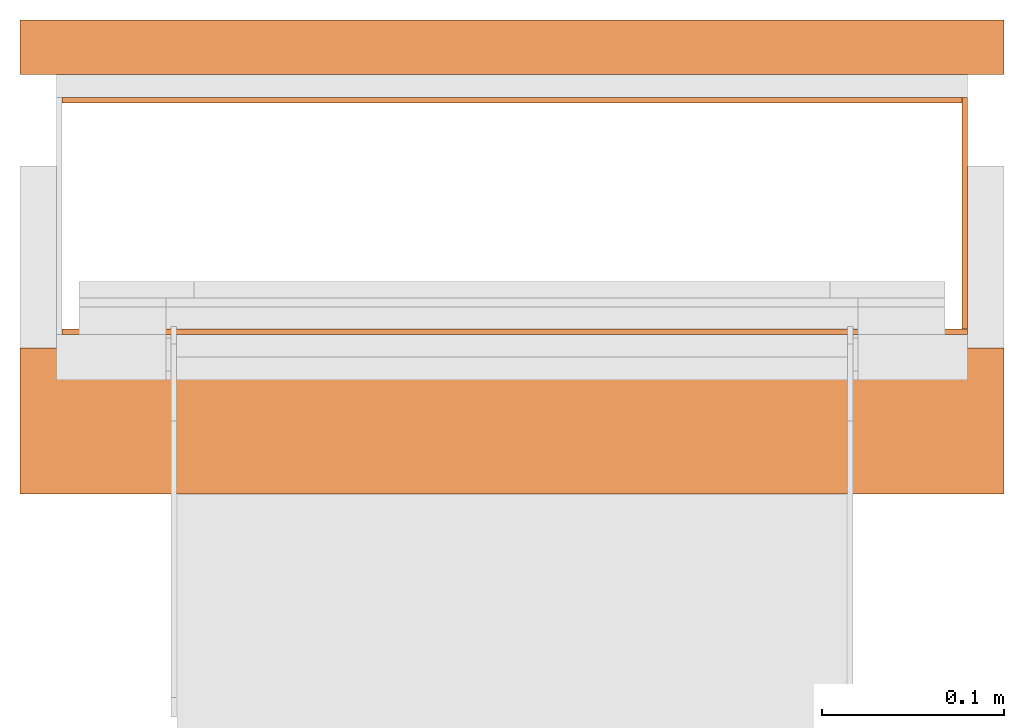
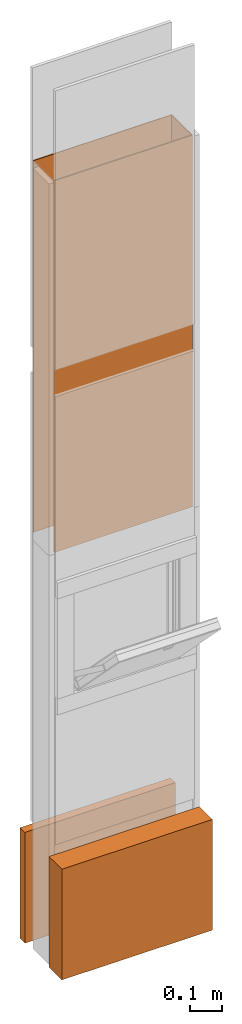
# One storey, part 3 of 3: 4 proxies.
"""IFC2X3 building model written with IfcOpenShell, lengths in metres."""

from ifc_helpers import new_model, entity, si_unit, converted_unit, derived_unit, money_unit, direction, frame, origin_with_axes, place, context, subcontext, project, spatial, polyline, outline, extrude, boolean, faceted_brep, material, type_object, element, save


model = new_model("IFC2X3")

# Units and contexts
model_context = context("Model", 3, precision=1e-05, world=origin_with_axes(), true_north=direction((0.0, 1.0)))
plan_context = context("Plan", 3, precision=1e-05, world=origin_with_axes(), true_north=direction((0.0, 1.0)))
body_context = subcontext(model_context, "Body", "Model", "MODEL_VIEW")
ifc_project = project(units=[si_unit("LENGTHUNIT", "METRE"), si_unit("AREAUNIT", "SQUARE_METRE"), si_unit("VOLUMEUNIT", "CUBIC_METRE"), converted_unit("PLANEANGLEUNIT", "DEGREE", entity("IfcPlaneAngleMeasure", 0.0174532925199), si_unit("PLANEANGLEUNIT", "RADIAN"), dimensions=[0, 0, 0, 0, 0, 0, 0]), si_unit("SOLIDANGLEUNIT", "STERADIAN"), money_unit("CHF"), converted_unit("TIMEUNIT", "Year", entity("IfcTimeMeasure", 31556926.0), si_unit("TIMEUNIT", "SECOND"), dimensions=[0, 0, 1, 0, 0, 0, 0]), si_unit("MASSUNIT", "GRAM", prefix="KILO"), si_unit("THERMODYNAMICTEMPERATUREUNIT", "DEGREE_CELSIUS"), si_unit("LUMINOUSINTENSITYUNIT", "LUMEN"), si_unit("ENERGYUNIT", "JOULE", prefix="MEGA"), derived_unit("THERMALCONDUCTANCEUNIT", [(si_unit("POWERUNIT", "WATT"), 1), (si_unit("LENGTHUNIT", "METRE"), -1), (si_unit("THERMODYNAMICTEMPERATUREUNIT", "KELVIN"), -1)]), derived_unit("SPECIFICHEATCAPACITYUNIT", [(si_unit("ENERGYUNIT", "JOULE"), 1), (si_unit("MASSUNIT", "GRAM", prefix="KILO"), -1), (si_unit("THERMODYNAMICTEMPERATUREUNIT", "KELVIN"), -1)]), derived_unit("MASSDENSITYUNIT", [(si_unit("MASSUNIT", "GRAM", prefix="KILO"), 1), (si_unit("VOLUMEUNIT", "CUBIC_METRE"), -1)])], contexts=[model_context, plan_context])

# Site, building, storey
site_placement = place(None, origin_with_axes())
site = spatial("IfcSite", under=ifc_project, at=site_placement, CompositionType="ELEMENT")
building_placement = place(site_placement, origin_with_axes())
building = spatial("IfcBuilding", under=site, at=building_placement, CompositionType="ELEMENT")
storey_placement = place(building_placement, frame((0.0, 0.0, 2.96), z_axis=(0.0, 0.0, 1.0), x_axis=(1.0, 0.0, 0.0)))
storey = spatial("IfcBuildingStorey", under=building, at=storey_placement, Name="OG01", CompositionType="ELEMENT", Elevation=2.96)

# Proxies
ifc_material_1 = material(Name="Metall, Stahl")
building_element_proxy_type_1 = type_object("IfcBuildingElementProxyType", Name="Metall, Stahl 3", PredefinedType="NOTDEFINED")
proxy_1_placement = place(storey_placement, frame((9.61522436818, -8.09743070606, 1.15), z_axis=(0.0, 0.0, 1.0), x_axis=(-1.0, 0.0, 0.0)))
element("IfcBuildingElementProxy", 1, at=proxy_1_placement, inside=storey, type_object=building_element_proxy_type_1, material=ifc_material_1, Name="Wand-008", context=body_context, shape_type="CSG", body=[
    boolean("DIFFERENCE", boolean("DIFFERENCE", extrude(outline(polyline([(0.0, 0.0), (0.5, 0.0), (0.5, 0.003), (0.0, 0.003), (0.0, 0.0)])), origin_with_axes(), (0.0, 0.0, 1.0), 1.41), faceted_brep([(0.497, 0.003, 1.41), (0.497, 0.0, 1.41), (0.5, 0.0, 1.41), (0.5, 0.003, 1.41), (0.497, 0.0, 0.0), (0.497, 0.003, 0.0), (0.5, 0.0, 0.0), (0.5, 0.003, 0.0)], [[[0, 1, 2, 3]], [[4, 1, 0, 5]], [[1, 4, 6, 2]], [[2, 6, 7, 3]], [[5, 0, 3, 7]], [[4, 5, 7, 6]]])), faceted_brep([(0.003, 0.0, 0.0), (0.003, 0.0, 1.41), (0.0, 0.0, 1.41), (0.0, 0.0, 0.0), (0.003, 0.003, 1.41), (0.003, 0.003, 0.0), (0.0, 0.003, 1.41), (0.0, 0.003, 0.0)], [[[0, 1, 2, 3]], [[4, 1, 0, 5]], [[1, 4, 6, 2]], [[6, 7, 3, 2]], [[5, 0, 3, 7]], [[4, 5, 7, 6]]])),
])
proxy_2_placement = place(storey_placement, frame((9.61522436818, -8.22743070606, 1.15), z_axis=(0.0, 0.0, 1.0), x_axis=(0.0, 1.0, 0.0)))
element("IfcBuildingElementProxy", 2, at=proxy_2_placement, inside=storey, type_object=building_element_proxy_type_1, material=ifc_material_1, Name="Wand-007", context=body_context, shape_type="CSG", body=[
    boolean("DIFFERENCE", extrude(outline(polyline([(0.0, 0.0), (0.13, 0.0), (0.13, 0.003), (0.0, 0.003), (0.0, 0.0)])), origin_with_axes(), (0.0, 0.0, 1.0), 1.41), faceted_brep([(0.003, 0.0, 0.0), (0.003, 0.0, 1.41), (0.0, 0.0, 1.41), (0.0, 0.0, 0.0), (0.003, 0.003, 1.41), (0.003, 0.003, 0.0), (0.0, 0.003, 1.41), (0.0, 0.003, 0.0)], [[[0, 1, 2, 3]], [[4, 1, 0, 5]], [[1, 4, 6, 2]], [[6, 7, 3, 2]], [[5, 0, 3, 7]], [[4, 5, 7, 6]]])),
])
proxy_3_placement = place(storey_placement, frame((9.11522436818, -8.22743070606, 1.15), z_axis=(0.0, 0.0, 1.0), x_axis=(1.0, 0.0, 0.0)))
element("IfcBuildingElementProxy", 3, at=proxy_3_placement, inside=storey, type_object=building_element_proxy_type_1, material=ifc_material_1, Name="Wand-006", context=body_context, shape_type="CSG", body=[
    boolean("DIFFERENCE", extrude(outline(polyline([(0.0, 0.0), (0.5, 0.0), (0.5, 0.003), (0.0, 0.003), (0.0, 0.0)])), origin_with_axes(), (0.0, 0.0, 1.0), 1.41), faceted_brep([(0.003, 0.0, 1.41), (0.003, 0.003, 1.41), (0.0, 0.003, 1.41), (0.0, 0.0, 1.41), (0.003, 0.003, 0.0), (0.003, 0.0, 0.0), (0.0, 0.003, 0.0), (0.0, 0.0, 0.0)], [[[0, 1, 2, 3]], [[4, 1, 0, 5]], [[1, 4, 6, 2]], [[2, 6, 7, 3]], [[5, 0, 3, 7]], [[4, 5, 7, 6]]])),
])
ifc_material_2 = material(Name="Luft, horizontal")
building_element_proxy_type_2 = type_object("IfcBuildingElementProxyType", Name="Luft, horizontal 420", PredefinedType="NOTDEFINED")
proxy_4_placement = place(storey_placement, frame((9.09522436818, -8.31493070606, 0.01), z_axis=(0.0, 0.0, 1.0), x_axis=(1.0, 0.0, 0.0)))
element("IfcBuildingElementProxy", 4, at=proxy_4_placement, inside=storey, type_object=building_element_proxy_type_2, material=ifc_material_2, Name="Decke-007", context=body_context, shape_type="CSG", body=[
    boolean("DIFFERENCE", extrude(outline(polyline([(0.0, 0.0), (0.54, 0.0), (0.54, 0.26), (0.0, 0.26), (0.0, 0.0)])), frame((0.0, 0.0, -0.42), z_axis=(0.0, 0.0, 1.0), x_axis=(1.0, 0.0, 0.0)), (0.0, 0.0, 1.0), 0.42), faceted_brep([(0.54, 0.23, -0.42), (0.54, 0.23, 0.0), (0.54, 0.08, 0.0), (0.54, 0.08, -0.42), (0.0, 0.23, 0.0), (0.0, 0.23, -0.42), (0.0, 0.08, 0.0), (0.0, 0.08, -0.42)], [[[0, 1, 2, 3]], [[4, 1, 0, 5]], [[1, 4, 6, 2]], [[3, 2, 6, 7]], [[5, 0, 3, 7]], [[4, 5, 7, 6]]])),
])

save(model, "model.ifc")
